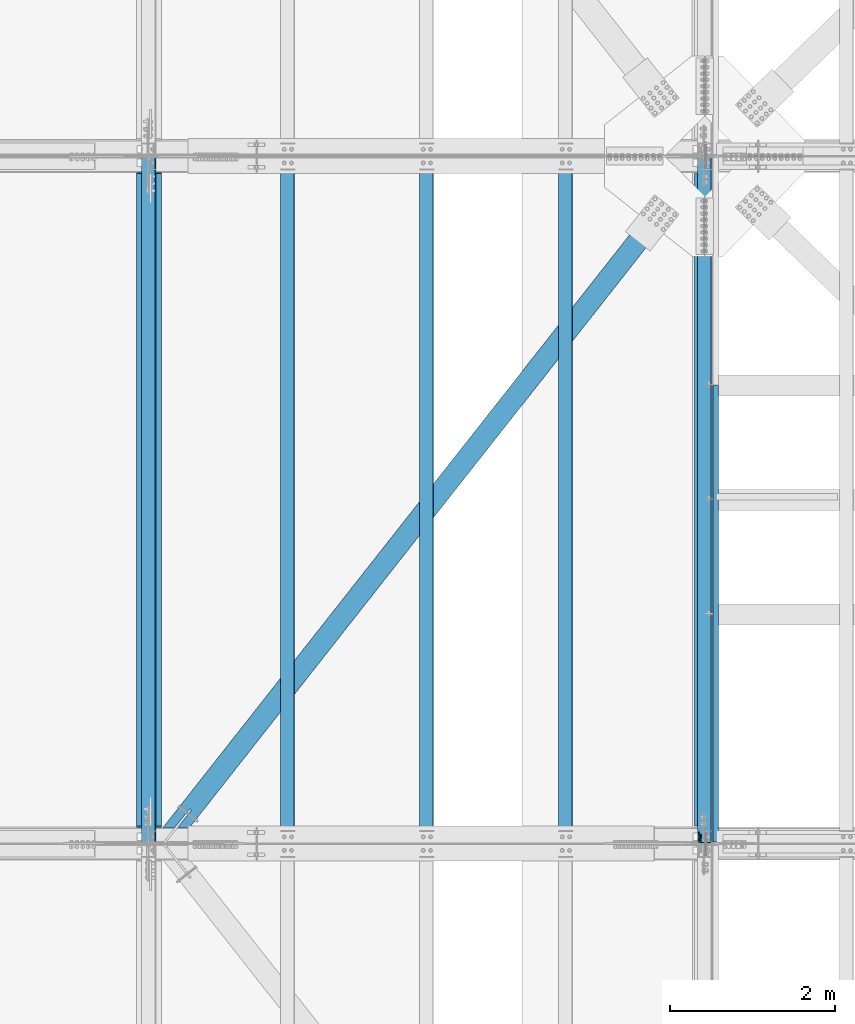
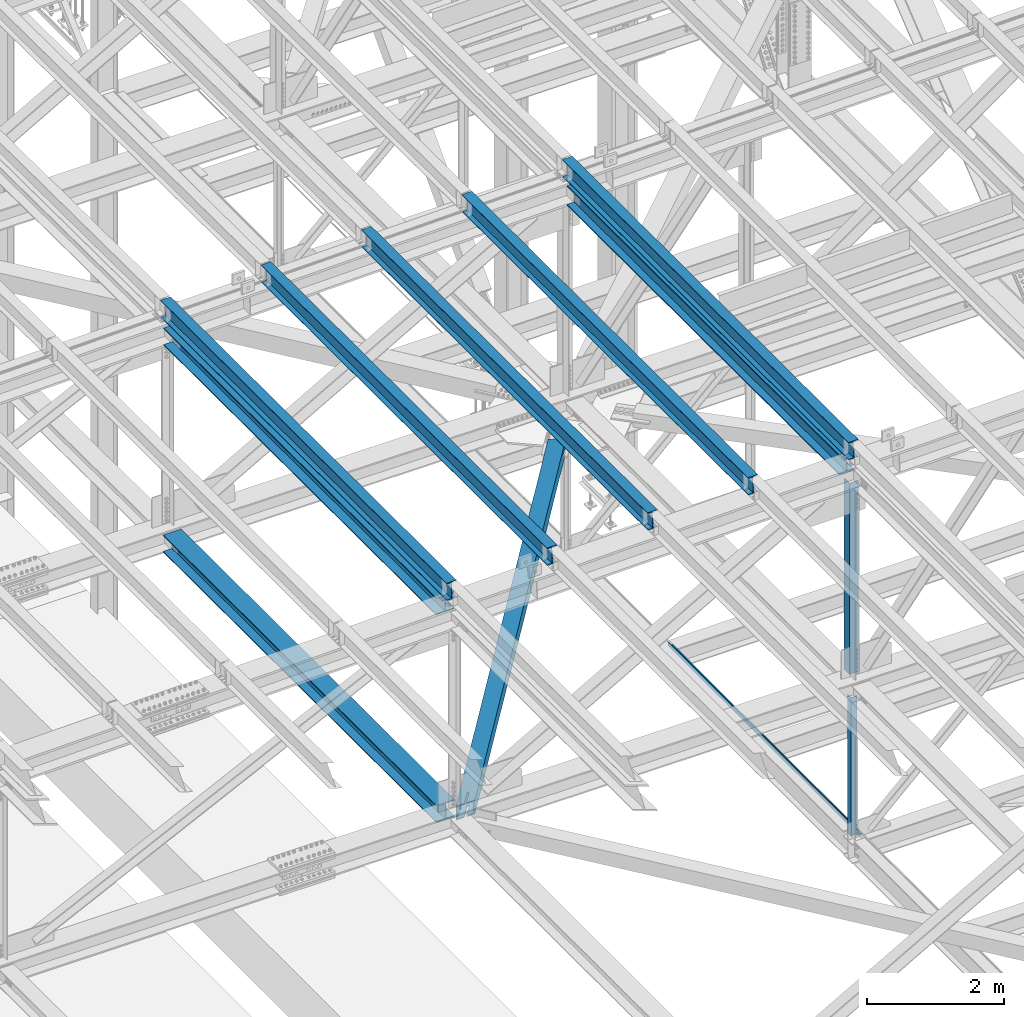
# One storey, part 1902 of 3843: 12 beams, 12 elements without a shape of their own.
"""IFC2X3 building model written with IfcOpenShell, lengths in millimetres."""

from ifc_helpers import new_model, si_unit, frame, origin_with_axes, place, context, subcontext, project, spatial, faceted_brep, material, type_object, element, aggregate, save


model = new_model("IFC2X3")

# Units and contexts
model_context = context("Model", 3, precision=1e-05, world=origin_with_axes())
body_context = subcontext(model_context, "Body", "Model", "MODEL_VIEW")
ifc_project = project(units=[si_unit("LENGTHUNIT", "METRE", prefix="MILLI"), si_unit("AREAUNIT", "SQUARE_METRE"), si_unit("VOLUMEUNIT", "CUBIC_METRE"), si_unit("MASSUNIT", "GRAM", prefix="KILO"), si_unit("TIMEUNIT", "SECOND"), si_unit("PLANEANGLEUNIT", "RADIAN"), si_unit("SOLIDANGLEUNIT", "STERADIAN"), si_unit("THERMODYNAMICTEMPERATUREUNIT", "DEGREE_CELSIUS"), si_unit("LUMINOUSINTENSITYUNIT", "LUMEN")], contexts=[model_context])

# Site, building, storey
site_placement = place(None, origin_with_axes())
site = spatial("IfcSite", under=ifc_project, at=site_placement, CompositionType="ELEMENT")
building_placement = place(site_placement, origin_with_axes())
building = spatial("IfcBuilding", under=site, at=building_placement, Name="Undefined", CompositionType="ELEMENT")
storey_placement = place(building_placement, origin_with_axes())
storey = spatial("IfcBuildingStorey", under=building, at=storey_placement, Name="Undefined", CompositionType="ELEMENT", Elevation=0.0)

# Assembly, beam
assembly_1_placement = place(storey_placement, origin_with_axes())
assembly_1 = element("IfcElementAssembly", 1, at=assembly_1_placement, inside=storey, Name="ANGLE", AssemblyPlace="NOTDEFINED", PredefinedType="RIGID_FRAME")
ifc_material_1 = material(Name="STEEL/A572-50")
beam_type_1 = type_object("IfcBeamType", Name="L4X4X3/8", PredefinedType="NOTDEFINED")
beam_1_placement = place(assembly_1_placement, frame((77012.8000007959, 67332.225, 42337.7620892171), z_axis=(0.0, 1.0, 0.0), x_axis=(0.0, 0.0, -1.0)))
beam_1 = element("IfcBeam", 2, at=beam_1_placement, type_object=beam_type_1, material=ifc_material_1, Name="ANGLE", ObjectType="L4X4X3/8", context=body_context, shape_type="Brep", body=[
    faceted_brep([(209.619404954581, 50.8000000000029, -50.8000000000029), (209.619404954581, 50.8000000000029, 50.8000000000029), (2671.51558679621, 50.8000000000029, 50.8000000000029), (2671.51558679621, 50.8000000000029, -50.8000000000029), (209.619404954581, 41.2749999999942, 50.8000000000029), (2671.51558679621, 41.2749999999942, 50.8000000000029), (209.619404954581, 41.2749999999942, -41.2749999999942), (2671.51558679621, 41.2749999999942, -41.2749999999942), (209.619404954581, -50.8000000000029, -41.2749999999942), (2671.51558679621, -50.8000000000029, -41.2749999999942), (209.619404954581, -50.8000000000029, -50.8000000000029), (2671.51558679621, -50.8000000000029, -50.8000000000029)], [[[0, 1, 2, 3]], [[1, 4, 5, 2]], [[4, 6, 7, 5]], [[6, 8, 9, 7]], [[8, 10, 11, 9]], [[10, 0, 3, 11]], [[5, 7, 9, 11, 3, 2]], [[10, 8, 6, 4, 1, 0]]]),
])
aggregate(assembly_1, [beam_1])

assembly_2_placement = place(storey_placement, origin_with_axes())
assembly_2 = element("IfcElementAssembly", 3, at=assembly_2_placement, inside=storey, Name="BEAM", AssemblyPlace="NOTDEFINED", PredefinedType="RIGID_FRAME")
ifc_material_2 = material(Name="STEEL/A992")
beam_type_2 = type_object("IfcBeamType", Name="W12X26", PredefinedType="NOTDEFINED")
beam_2_placement = place(assembly_2_placement, frame((77009.5092623547, 67272.2367402052, 46520.5581459904), z_axis=(-0.02115209757931, 0.00216448800069338, 0.999773926325192), x_axis=(0.0, 0.999997656445371, -0.00216497200096435)))
beam_2 = element("IfcBeam", 4, at=beam_2_placement, type_object=beam_type_2, material=ifc_material_2, Name="BEAM", ObjectType="W12X26", context=body_context, shape_type="Brep", body=[
    faceted_brep([(12.7037963889888, 82.550000000585, -155.57500000039), (12.683193207602, 82.5500000002357, -146.050000000549), (8343.90271783868, 82.5500000001048, -146.049999994), (8343.92333463172, 82.5500000000757, -155.574999994024), (12.6795583240309, 3.17499999979918, -146.050000000425), (8343.8990829551, 3.17499999965366, -146.049999993877), (12.0473100042, 3.17500000025029, 146.050000000447), (8343.26683463529, 3.17500000011933, 146.050000006988), (12.050944887771, 82.5500000007014, 146.050000000316), (8343.27046951886, 82.5500000005559, 146.050000006871), (12.0303280947264, 82.5500000007014, 155.575000000354), (8343.24985272581, 82.5500000005704, 155.575000006902), (12.0227675369097, -82.5500000002212, 155.575000000594), (8343.24229216801, -82.5500000003667, 155.575000007149), (12.0433843299543, -82.5500000002357, 146.05000000057), (8343.26290896104, -82.5500000003813, 146.050000007119), (12.0470192135253, -3.17499999978463, 146.050000000454), (8343.26654384461, -3.17499999993015, 146.050000006995), (12.6792675333563, -3.17500000025029, -146.050000000425), (8343.89879216443, -3.17500000038126, -146.049999993869), (12.6756326497853, -82.5500000006869, -146.050000000301), (8343.89510752616, -82.549999962459, -146.049999975388), (12.6962628250476, -82.5500000003522, -155.574999999924), (8343.9157740739, -82.5500000008324, -155.574999993776)], [[[0, 1, 2, 3]], [[1, 4, 5, 2]], [[4, 6, 7, 5]], [[6, 8, 9, 7]], [[8, 10, 11, 9]], [[10, 12, 13, 11]], [[12, 14, 15, 13]], [[14, 16, 17, 15]], [[16, 18, 19, 17]], [[18, 20, 21, 19]], [[20, 22, 23, 21]], [[22, 0, 3, 23]], [[5, 7, 9, 11, 13, 15, 17, 19, 21, 23, 3, 2]], [[22, 20, 18, 16, 14, 12, 10, 8, 6, 4, 1, 0]]]),
])
aggregate(assembly_2, [beam_2])

assembly_3_placement = place(storey_placement, origin_with_axes())
assembly_3 = element("IfcElementAssembly", 5, at=assembly_3_placement, inside=storey, Name="BEAM", AssemblyPlace="NOTDEFINED", PredefinedType="RIGID_FRAME")
beam_3_placement = place(assembly_3_placement, frame((70253.109262355, 67272.2253246487, 46384.0531792137), z_axis=(-0.0211520982737129, 0.00209111100100563, 0.999774082477337), x_axis=(0.0, 0.999997812646253, -0.00209157899925994)))
beam_3 = element("IfcBeam", 6, at=beam_3_placement, type_object=beam_type_2, material=ifc_material_2, Name="BEAM", ObjectType="W12X26", context=body_context, shape_type="Brep", body=[
    faceted_brep([(12.7036798584013, 82.5500000007596, -155.574999999946), (12.6837619820581, 82.5500000007451, -146.049999999937), (8343.90198525623, 82.5500000010506, -146.050000014387), (8343.92190313258, 82.5500000010652, -155.575000014403), (12.6802503225917, 3.1750000003085, -146.050000000148), (8343.89847359677, 3.17500000061409, -146.050000014606), (12.0694354482985, 3.17499999974098, 146.050000000119), (8343.28765872247, 3.17500000004657, 146.049999985662), (12.0729471077648, 82.5500000001775, 146.050000000338), (8343.29117038194, 82.5500000004831, 146.04999998588), (12.0530292314361, 82.550000000163, 155.575000000346), (8343.2712525056, 82.5500000004831, 155.574999985889), (12.0457249797328, -82.5500000007596, 155.574999999895), (8343.26394825391, -82.550000000454, 155.574999985445), (12.065642856076, -82.5500000007451, 146.049999999886), (8343.28386613025, -82.5500000004395, 146.049999985436), (12.0691545155423, -3.17500000029395, 146.050000000105), (8343.28737778972, -3.17499999998836, 146.049999985647), (12.6799693898356, -3.17499999974098, -146.05000000017), (8343.89819266401, -3.17499999943539, -146.050000014628), (12.6764577303547, -82.5500000001921, -146.050000000381), (8343.89468100455, -82.5499999998865, -146.050000014839), (12.696375606698, -82.550000000163, -155.57500000039), (8343.91459888089, -82.5499999998574, -155.575000014847)], [[[0, 1, 2, 3]], [[1, 4, 5, 2]], [[4, 6, 7, 5]], [[6, 8, 9, 7]], [[8, 10, 11, 9]], [[10, 12, 13, 11]], [[12, 14, 15, 13]], [[14, 16, 17, 15]], [[16, 18, 19, 17]], [[18, 20, 21, 19]], [[20, 22, 23, 21]], [[22, 0, 3, 23]], [[5, 7, 9, 11, 13, 15, 17, 19, 21, 23, 3, 2]], [[22, 20, 18, 16, 14, 12, 10, 8, 6, 4, 1, 0]]]),
])
aggregate(assembly_3, [beam_3])

assembly_4_placement = place(storey_placement, origin_with_axes())
assembly_4 = element("IfcElementAssembly", 7, at=assembly_4_placement, inside=storey, Name="BEAM", AssemblyPlace="NOTDEFINED", PredefinedType="RIGID_FRAME")
beam_4_placement = place(assembly_4_placement, frame((75320.4094463182, 67272.2363840141, 46487.3259265491), z_axis=(-0.0211520975208841, 0.00216219800061662, 0.999773931281604), x_axis=(-2.1999999147417e-08, 0.999997661398384, -0.00216268300086169)))
beam_4 = element("IfcBeam", 8, at=beam_4_placement, type_object=beam_type_2, material=ifc_material_2, Name="BEAM", ObjectType="W12X26", context=body_context, shape_type="Brep", body=[
    faceted_brep([(12.7037963889888, 82.550000000585, -155.57500000039), (12.6832505025814, 82.550000000585, -146.050000000381), (8343.90271783868, 82.5500000001048, -146.049999994), (8343.92333463172, 82.5500000000757, -155.574999994024), (12.6796285968449, 3.17500000013388, -146.050000000163), (8343.89901918435, 3.17500003804162, -146.049999975628), (12.0480003569392, 3.17500000042492, 146.04999999969), (8343.26748387654, 3.17500002078305, 146.050000020252), (12.0516331437248, 82.550000000876, 146.049999999414), (8343.27111666334, 82.5500000212342, 146.050000019983), (12.0310381532472, 82.5500000009051, 155.574999999386), (8343.25052167283, 82.5500000212778, 155.575000019962), (12.0234819566831, -82.550000000032, 155.574999999953), (8343.24296547628, -82.5499999796739, 155.57500002053), (12.0440769471606, -82.5500000000611, 146.049999999988), (8343.26356046677, -82.549999979703, 146.050000020543), (12.0477097339899, -3.17499999961001, 146.049999999705), (8343.26719325357, -3.17499997923733, 146.050000020281), (12.6793388443766, -3.1749999999156, -146.050000000141), (8343.89872943189, -3.17499996200786, -146.049999975599), (12.6756326497853, -82.5500000006869, -146.050000000301), (8343.89510752616, -82.549999962459, -146.049999975388), (12.6962628250476, -82.5500000003522, -155.574999999924), (8343.9157740739, -82.5500000008324, -155.574999993776)], [[[0, 1, 2, 3]], [[1, 4, 5, 2]], [[4, 6, 7, 5]], [[6, 8, 9, 7]], [[8, 10, 11, 9]], [[10, 12, 13, 11]], [[12, 14, 15, 13]], [[14, 16, 17, 15]], [[16, 18, 19, 17]], [[18, 20, 21, 19]], [[20, 22, 23, 21]], [[22, 0, 3, 23]], [[5, 7, 9, 11, 13, 15, 17, 19, 21, 23, 3, 2]], [[22, 20, 18, 16, 14, 12, 10, 8, 6, 4, 1, 0]]]),
])
aggregate(assembly_4, [beam_4])

assembly_5_placement = place(storey_placement, origin_with_axes())
assembly_5 = element("IfcElementAssembly", 9, at=assembly_5_placement, inside=storey, Name="BEAM", AssemblyPlace="NOTDEFINED", PredefinedType="RIGID_FRAME")
beam_5_placement = place(assembly_5_placement, frame((73631.3092623312, 67272.2334284591, 46453.4642094914), z_axis=(-0.0211520976140747, 0.00214229500025977, 0.99977397412548), x_axis=(-2.20000000902242e-08, 0.999997704255013, -0.00214277500054673)))
beam_5 = element("IfcBeam", 10, at=beam_5_placement, type_object=beam_type_2, material=ifc_material_2, Name="BEAM", ObjectType="W12X26", context=body_context, shape_type="Brep", body=[
    faceted_brep([(12.7037963889888, 82.550000000585, -155.57500000039), (12.68336709289, 82.5499999996246, -146.050000000039), (8343.90246569729, 82.5499999989333, -146.049999980707), (8343.92289895112, 82.5500000208558, -155.575000023666), (12.6797677313734, 3.17499999917345, -146.049999999879), (8343.89889418155, 3.1750000204629, -146.050000023519), (12.0537287846819, 3.1750000006723, 146.05000000052), (8343.27287122235, 3.17500000084692, 146.049999992661), (12.0573279195814, 82.5500000011234, 146.050000000359), (8343.27647035726, 82.550000001298, 146.049999992501), (12.0369138889801, 82.5500000011671, 155.575000000397), (8343.25605632665, 82.5500000013417, 155.574999992539), (12.0294276883797, -82.5499999997555, 155.57500000071), (8343.24857012604, -82.5499999995955, 155.574999992859), (12.049841718981, -82.5499999997992, 146.05000000068), (8343.26898415665, -82.5499999996246, 146.049999992829), (12.0534408538806, -3.17499999934807, 146.05000000052), (8343.27258329155, -3.17499999917345, 146.049999992669), (12.679479782455, -3.17500000086147, -146.049999999857), (8343.89860623263, -3.17499997957202, -146.050000023497), (12.6758804209385, -82.550000001298, -146.049999999705), (8343.89500687108, -82.5499999800086, -146.050000023337), (12.6962628250476, -82.5500000003522, -155.574999999924), (8343.91541227915, -82.5499999800668, -155.575000023331)], [[[0, 1, 2, 3]], [[1, 4, 5, 2]], [[4, 6, 7, 5]], [[6, 8, 9, 7]], [[8, 10, 11, 9]], [[10, 12, 13, 11]], [[12, 14, 15, 13]], [[14, 16, 17, 15]], [[16, 18, 19, 17]], [[18, 20, 21, 19]], [[20, 22, 23, 21]], [[22, 0, 3, 23]], [[5, 7, 9, 11, 13, 15, 17, 19, 21, 23, 3, 2]], [[22, 20, 18, 16, 14, 12, 10, 8, 6, 4, 1, 0]]]),
])
aggregate(assembly_5, [beam_5])

assembly_6_placement = place(storey_placement, origin_with_axes())
assembly_6 = element("IfcElementAssembly", 11, at=assembly_6_placement, inside=storey, Name="BEAM", AssemblyPlace="NOTDEFINED", PredefinedType="RIGID_FRAME")
beam_6_placement = place(assembly_6_placement, frame((71942.2094462516, 67272.2310134095, 46419.0794002078), z_axis=(-0.0211520979537891, 0.00212767700070982, 0.999774005334573), x_axis=(-2.20000007768643e-08, 0.99999773547771, -0.00212815400101693)))
beam_6 = element("IfcBeam", 12, at=beam_6_placement, type_object=beam_type_2, material=ifc_material_2, Name="BEAM", ObjectType="W12X26", context=body_context, shape_type="Brep", body=[
    faceted_brep([(12.7037963889888, 82.550000000585, -155.57500000039), (12.683480394975, 82.5500000002939, -146.049999999464), (8343.90234657429, 82.5500000214379, -146.050000015632), (8343.92261274744, 82.5500000214088, -155.575000015604), (12.6799055809533, 3.17499999984284, -146.049999999574), (8343.89877176027, 3.17500002098677, -146.050000015734), (12.058409604826, 3.17500000023574, 146.049999999545), (8343.27727578412, 3.17500002136512, 146.049999983385), (12.0619844188186, 82.5500000006869, 146.049999999639), (8343.28085059814, 82.5500000218162, 146.049999983486), (12.0417182456877, 82.5500000006869, 155.574999999611), (8343.26058442501, 82.5500000218308, 155.574999983459), (12.0342826325505, -82.5500000002357, 155.574999999408), (8343.25314881184, -82.5499999790918, 155.574999983255), (12.0545488056814, -82.5500000002503, 146.049999999435), (8343.27341498497, -82.5499999791209, 146.049999983283), (12.0581236196886, -3.17499999979918, 146.049999999545), (8343.27698979899, -3.1749999786698, 146.049999983377), (12.6796195958304, -3.17500000017753, -146.049999999581), (8343.89848577516, -3.1749999790336, -146.050000015734), (12.6760447818233, -82.5500000006286, -146.049999999683), (8343.89491096114, -82.5499999794847, -146.050000015828), (12.6962628250476, -82.5500000003522, -155.574999999924), (8343.91517713427, -82.5499999795138, -155.5750000158)], [[[0, 1, 2, 3]], [[1, 4, 5, 2]], [[4, 6, 7, 5]], [[6, 8, 9, 7]], [[8, 10, 11, 9]], [[10, 12, 13, 11]], [[12, 14, 15, 13]], [[14, 16, 17, 15]], [[16, 18, 19, 17]], [[18, 20, 21, 19]], [[20, 22, 23, 21]], [[22, 0, 3, 23]], [[5, 7, 9, 11, 13, 15, 17, 19, 21, 23, 3, 2]], [[22, 20, 18, 16, 14, 12, 10, 8, 6, 4, 1, 0]]]),
])
aggregate(assembly_6, [beam_6])

assembly_7_placement = place(storey_placement, origin_with_axes())
assembly_7 = element("IfcElementAssembly", 13, at=assembly_7_placement, inside=storey, Name="BENT_PLATE", AssemblyPlace="NOTDEFINED", PredefinedType="RIGID_FRAME")
ifc_material_3 = material(Name="STEEL/A36")
beam_type_3 = type_object("IfcBeamType", PredefinedType="NOTDEFINED")
beam_7_placement = place(assembly_7_placement, frame((77179.4875000013, 70066.69375, 39627.1749999995), z_axis=(0.0, 1.0, 0.0), x_axis=(-1.0, 0.0, 0.0)))
beam_7 = element("IfcBeam", 14, at=beam_7_placement, type_object=beam_type_3, material=ifc_material_3, Name="BENT_PLATE", context=body_context, shape_type="Brep", body=[
    faceted_brep([(0.0, -3.17500000000291, -2776.53750000001), (0.0, -3.17500000000291, 2776.53750000001), (0.0, 3.17500000000291, 2776.53750000001), (0.0, 3.17500000000291, -2776.53750000001), (69.8500000010827, 3.17500000000291, 2776.53750000001), (69.8500000010827, 3.17500000000291, -2776.53750000001), (76.2000000010739, -3.17500000000291, -2776.53750000001), (76.2000000010739, -3.17500000000291, 2776.53750000001), (69.8500000011554, 73.0249999989392, 2776.53750000001), (69.8500000011554, 73.0249999989392, -2776.53750000001), (76.2000000011612, 73.0249999989246, 2776.53750000001), (76.2000000011612, 73.0249999989246, -2776.53750000001)], [[[0, 1, 2, 3]], [[3, 2, 4, 5]], [[1, 0, 6, 7]], [[5, 4, 8, 9]], [[4, 2, 1, 7, 10, 8]], [[7, 6, 11, 10]], [[6, 0, 3, 5, 9, 11]], [[10, 11, 9, 8]]]),
])
aggregate(assembly_7, [beam_7])

assembly_8_placement = place(storey_placement, origin_with_axes())
assembly_8 = element("IfcElementAssembly", 15, at=assembly_8_placement, inside=storey, Name="ANGLE", AssemblyPlace="NOTDEFINED", PredefinedType="RIGID_FRAME")
beam_type_4 = type_object("IfcBeamType", Name="L6X6X1/2", PredefinedType="NOTDEFINED")
beam_8_placement = place(assembly_8_placement, frame((77012.7999988756, 67357.625, 46168.1307259776), z_axis=(0.0, 1.0, 0.0), x_axis=(0.0, 0.0, -1.0)))
beam_8 = element("IfcBeam", 16, at=beam_8_placement, type_object=beam_type_4, material=ifc_material_1, Name="ANGLE", ObjectType="L6X6X1/2", context=body_context, shape_type="Brep", body=[
    faceted_brep([(223.145843578597, 76.1999999999971, -76.1999999999971), (223.145843578597, 76.1999999999971, 76.1999999999971), (3620.01394118612, 76.1999999999971, 76.1999999999971), (3620.01394118612, 76.1999999999971, -76.1999999999971), (223.145843578597, 63.5, 76.1999999999971), (3620.01394118612, 63.5, 76.1999999999971), (223.145843578597, 63.5, -63.5), (3620.01394118612, 63.5, -63.5), (223.145843578597, -76.1999999999971, -63.5), (3620.01394118612, -76.1999999999971, -63.5), (223.145843578597, -76.1999999999971, -76.1999999999971), (3620.01394118612, -76.1999999999971, -76.1999999999971)], [[[0, 1, 2, 3]], [[1, 4, 5, 2]], [[4, 6, 7, 5]], [[6, 8, 9, 7]], [[8, 10, 11, 9]], [[10, 0, 3, 11]], [[5, 7, 9, 11, 3, 2]], [[10, 8, 6, 4, 1, 0]]]),
])
aggregate(assembly_8, [beam_8])

assembly_9_placement = place(storey_placement, origin_with_axes())
assembly_9 = element("IfcElementAssembly", 17, at=assembly_9_placement, inside=storey, AssemblyPlace="NOTDEFINED", PredefinedType="RIGID_FRAME")
ifc_material_4 = material()
beam_type_5 = type_object("IfcBeamType", Name="HSS10X10X3/4", PredefinedType="NOTDEFINED")
beam_9_placement = place(assembly_9_placement, frame((70434.2, 67271.9, 42246.55), z_axis=(0.785737878354044, -0.61855960627872, 0.0), x_axis=(0.618559606278724, 0.785737878354041, 0.0)))
beam_9 = element("IfcBeam", 18, at=beam_9_placement, type_object=beam_type_5, material=ifc_material_4, ObjectType="HSS10X10X3/4", context=body_context, shape_type="Brep", body=[
    faceted_brep([(516.209344809561, -107.949999999997, 14.2875004909001), (516.209344809561, -127.0, 14.2875004909001), (263.796845348849, -127.0, 14.2875004904345), (263.796845348849, -107.949999999997, 14.2875004904345), (521.676934495421, -107.949999999997, 13.1999292826367), (521.676934495421, -127.0, 13.1999292826367), (526.312133215446, -107.949999999997, 10.1027885154035), (526.312133215446, -127.0, 10.1027885154035), (529.409273982694, -107.949999999997, 5.46758979538572), (529.409273982694, -127.0, 5.46758979538572), (516.209344809772, -127.0, -14.2874995075981), (516.209344809772, -107.949999999997, -14.2874995075981), (241.301632587426, -107.949999999997, -14.2874995080638), (241.301632587426, -127.0, -14.2874995080638), (521.676934495611, -127.0, -13.1999282993202), (521.676934495611, -107.949999999997, -13.1999282993202), (526.312133215585, -127.0, -10.1027875320869), (526.312133215585, -107.949999999997, -10.1027875320869), (529.40927398276, -127.0, -5.4675888120546), (529.40927398276, -107.949999999997, -5.4675888120546), (530.496845191009, -127.0, 1.09503162093461e-07), (530.496845191009, -107.949999999997, 1.09503162093461e-07), (516.209344809561, 127.0, 14.2875004909001), (516.209344809561, 107.949999999997, 14.2875004909001), (263.796845348849, 107.949999999997, 14.2875004904345), (263.796845348849, 127.0, 14.2875004904345), (521.676934495421, 127.0, 13.1999292826367), (521.676934495421, 107.949999999997, 13.1999292826367), (526.312133215446, 127.0, 10.1027885154035), (526.312133215446, 107.949999999997, 10.1027885154035), (529.409273982694, 127.0, 5.46758979538572), (529.409273982694, 107.949999999997, 5.46758979538572), (516.209344809772, 107.949999999997, -14.2874995075981), (516.209344809772, 127.0, -14.2874995075981), (241.301632587426, 127.0, -14.2874995080638), (241.301632587426, 107.949999999997, -14.2874995080638), (521.676934495611, 107.949999999997, -13.1999282993202), (521.676934495611, 127.0, -13.1999282993202), (526.312133215585, 107.949999999997, -10.1027875320869), (526.312133215585, 127.0, -10.1027875320869), (529.40927398276, 107.949999999997, -5.4675888120546), (529.40927398276, 127.0, -5.4675888120546), (530.496845191009, 107.949999999997, 1.09503162093461e-07), (530.496845191009, 127.0, 1.09503162093461e-07), (9318.00077363143, -1.58687290176022, -107.950000040411), (9318.00077363134, -1.58687290176022, -127.000000040291), (9312.53318394556, -0.49930169347499, -127.000000040276), (9312.53318394565, -0.49930169347499, -107.95000004039), (9307.89798522559, 2.5978390737655, -127.000000040247), (9307.89798522567, 2.5978390737655, -107.950000040368), (9304.80084445841, 7.2330377938124, -127.000000040247), (9304.8008444585, 7.2330377938124, -107.950000040353), (9303.71327325016, 12.7006267167671, -127.000000040232), (9303.71327325022, 12.7006267167671, -107.950000040353), (9304.80084445841, 18.1682164026643, -127.000000040247), (9304.8008444585, 18.1682164026643, -107.950000040353), (9307.89798522559, 22.8034151227112, -127.000000040247), (9307.89798522567, 22.8034151227112, -107.950000040368), (9312.53318394556, 25.9005558899516, -127.000000040276), (9312.53318394565, 25.9005558899516, -107.95000004039), (9318.00077363134, 26.9881270982369, -127.000000040291), (9318.00077363143, 26.9881270982369, -107.950000040411), (9570.41327335576, 26.9881270982369, -127.000000041411), (9570.41327335576, 26.9881270982369, -107.950000041532), (337.531153461072, -107.949999999997, 107.949999998338), (337.531153461072, 107.949999999997, 107.949999998338), (9570.41327454061, 107.949999999997, 107.950000042016), (9570.41327335578, 26.9881270982369, 107.949999957153), (9318.00077363239, 26.9881270982369, 107.949999958259), (9312.53318394658, 25.9005558899516, 107.949999958288), (9307.89798522663, 22.8034151227112, 107.949999958302), (9304.80084445943, 18.1682164026643, 107.949999958324), (9303.71327325118, 12.7006267167671, 107.949999958324), (9304.80084445943, 7.2330377938124, 107.949999958324), (9307.89798522663, 2.5978390737655, 107.949999958302), (9312.53318394658, -0.49930169347499, 107.949999958288), (9318.00077363239, -1.58687290176022, 107.949999958259), (9570.41327335578, -1.58687290176022, 107.949999957153), (9570.41327454061, -107.949999999997, 107.950000042016), (9570.41327467293, -107.949999999997, -107.949999957629), (167.56732370008, -107.949999999997, -107.950000000565), (9570.41327467293, 107.949999999997, -107.949999957629), (167.56732370008, 107.949999999997, -107.950000000565), (9570.41327335576, -1.58687290176022, -107.950000041532), (9570.41327335576, -1.58687290176022, -127.000000041411), (152.570515191763, -127.0, -127.000000000466), (152.570515191763, 127.0, -127.000000000466), (9570.4132746846, 127.0, -126.999999957603), (9570.4132746846, -127.0, -126.999999957603), (352.527961969396, 127.0, 126.999999998239), (9570.41327452892, 127.0, 127.000000041982), (9570.41327335578, 26.9881270982369, 126.999999957025), (9318.00077363248, 26.9881270982369, 126.999999958145), (9312.53318394667, 25.9005558899516, 126.99999995816), (9307.89798522672, 22.8034151227112, 126.999999958189), (9304.80084445952, 18.1682164026643, 126.999999958189), (9303.71327325127, 12.7006267167671, 126.999999958211), (9304.80084445952, 7.2330377938124, 126.999999958189), (9307.89798522672, 2.5978390737655, 126.999999958189), (9312.53318394667, -0.49930169347499, 126.99999995816), (9318.00077363248, -1.58687290176022, 126.999999958145), (9570.41327335578, -1.58687290176022, 126.999999957025), (9570.41327452892, -127.0, 127.000000041982), (352.527961969396, -127.0, 126.999999998239)], [[[0, 1, 2, 3]], [[1, 0, 4, 5]], [[5, 4, 6, 7]], [[7, 6, 8, 9]], [[10, 11, 12, 13]], [[14, 15, 11, 10]], [[16, 17, 15, 14]], [[18, 19, 17, 16]], [[20, 21, 19, 18]], [[9, 8, 21, 20]], [[22, 23, 24, 25]], [[23, 22, 26, 27]], [[27, 26, 28, 29]], [[29, 28, 30, 31]], [[32, 33, 34, 35]], [[36, 37, 33, 32]], [[38, 39, 37, 36]], [[40, 41, 39, 38]], [[42, 43, 41, 40]], [[31, 30, 43, 42]], [[44, 45, 46, 47]], [[47, 46, 48, 49]], [[49, 48, 50, 51]], [[51, 50, 52, 53]], [[53, 52, 54, 55]], [[55, 54, 56, 57]], [[57, 56, 58, 59]], [[59, 58, 60, 61]], [[61, 60, 62, 63]], [[64, 65, 66, 67, 68, 69, 70, 71, 72, 73, 74, 75, 76, 77, 78]], [[6, 4, 0, 3, 64, 78, 79, 80, 12, 11, 15, 17, 19, 21, 8]], [[44, 47, 49, 51, 53, 55, 57, 59, 61, 63, 81, 82, 80, 79, 83]], [[45, 44, 83, 84]], [[85, 86, 87, 62, 60, 58, 56, 54, 52, 50, 48, 46, 45, 84, 88]], [[80, 82, 35, 34, 86, 85, 13, 12]], [[28, 26, 22, 25, 89, 90, 87, 86, 34, 33, 37, 39, 41, 43, 30]], [[66, 81, 63, 62, 87, 90, 91, 67]], [[92, 68, 67, 91]], [[93, 69, 68, 92]], [[94, 70, 69, 93]], [[95, 71, 70, 94]], [[96, 72, 71, 95]], [[97, 73, 72, 96]], [[98, 74, 73, 97]], [[99, 75, 74, 98]], [[100, 76, 75, 99]], [[76, 100, 101, 77]], [[84, 83, 79, 78, 77, 101, 102, 88]], [[100, 99, 98, 97, 96, 95, 94, 93, 92, 91, 90, 89, 103, 102, 101]], [[16, 14, 10, 13, 85, 88, 102, 103, 2, 1, 5, 7, 9, 20, 18]], [[25, 24, 65, 64, 3, 2, 103, 89]], [[38, 36, 32, 35, 82, 81, 66, 65, 24, 23, 27, 29, 31, 42, 40]]]),
])
aggregate(assembly_9, [beam_9])

assembly_10_placement = place(storey_placement, origin_with_axes())
assembly_10 = element("IfcElementAssembly", 19, at=assembly_10_placement, inside=storey, Name="BEAM", AssemblyPlace="NOTDEFINED", PredefinedType="RIGID_FRAME")
beam_type_6 = type_object("IfcBeamType", Name="W14X68", PredefinedType="NOTDEFINED")
beam_10_placement = place(assembly_10_placement, frame((77012.8, 67271.8999999987, 46168.1307546954), z_axis=(0.0, 0.0021649720009591, 0.999997656445371), x_axis=(0.0, 0.999997656445371, -0.00216497200096435)))
beam_10 = element("IfcBeam", 20, at=beam_10_placement, type_object=beam_type_6, material=ifc_material_2, Name="BEAM", ObjectType="W14X68", context=body_context, shape_type="Brep", body=[
    faceted_brep([(213.110431458015, 127.0, -177.799999999428), (213.069188644731, 127.0, -158.749999999469), (8144.23777573642, 127.0, -158.749999993241), (8144.27901854969, 127.0, -177.799999993193), (213.069188644731, 5.55624999999418, -158.749999999469), (8144.23777573642, 5.55624999999418, -158.749999993241), (212.381808423524, 5.55624999999418, 158.749999999825), (8143.55039551521, 5.55624999999418, 158.750000006054), (212.381808423524, 127.0, 158.749999999825), (8143.55039551521, 127.0, 158.750000006054), (212.34056561024, 127.0, 177.799999999785), (8143.50915270194, 127.0, 177.800000006013), (212.34056561024, -127.0, 177.799999999785), (8143.50915270194, -127.0, 177.800000006013), (212.381808423524, -127.0, 158.749999999825), (8143.55039551521, -127.0, 158.750000006054), (212.381808423524, -5.55624999999418, 158.749999999825), (8143.55039551521, -5.55624999999418, 158.750000006054), (213.069188644731, -5.55624999999418, -158.749999999469), (8144.23777573642, -5.55624999999418, -158.749999993241), (213.069188644731, -127.0, -158.749999999469), (8144.23777573642, -127.0, -158.749999993241), (213.110431458015, -127.0, -177.799999999428), (8144.27901854969, -127.0, -177.799999993193)], [[[0, 1, 2, 3]], [[1, 4, 5, 2]], [[4, 6, 7, 5]], [[6, 8, 9, 7]], [[8, 10, 11, 9]], [[10, 12, 13, 11]], [[12, 14, 15, 13]], [[14, 16, 17, 15]], [[16, 18, 19, 17]], [[18, 20, 21, 19]], [[20, 22, 23, 21]], [[22, 0, 3, 23]], [[5, 7, 9, 11, 13, 15, 17, 19, 21, 23, 3, 2]], [[22, 20, 18, 16, 14, 12, 10, 8, 6, 4, 1, 0]]]),
])
aggregate(assembly_10, [beam_10])

assembly_11_placement = place(storey_placement, origin_with_axes())
assembly_11 = element("IfcElementAssembly", 21, at=assembly_11_placement, inside=storey, Name="BEAM", AssemblyPlace="NOTDEFINED", PredefinedType="RIGID_FRAME")
beam_type_7 = type_object("IfcBeamType", Name="W12X65", PredefinedType="NOTDEFINED")
beam_11_placement = place(assembly_11_placement, frame((70256.4, 67271.8999999994, 46031.6211476753), z_axis=(0.0, 0.00209157899925776, 0.999997812646253), x_axis=(0.0, 0.999997812646253, -0.00209157899925994)))
beam_11 = element("IfcBeam", 22, at=beam_11_placement, type_object=beam_type_7, material=ifc_material_2, Name="BEAM", ObjectType="W12X65", context=body_context, shape_type="Brep", body=[
    faceted_brep([(213.047543032008, 152.399999999994, -153.987499999923), (213.014339142654, 152.399999999994, -138.112499999967), (8144.18168736623, 152.399999999994, -138.112500013733), (8144.21489125559, 152.399999999994, -153.987500013689), (213.014339142654, 4.76249999999709, -138.112499999967), (8144.18168736623, 4.76249999999709, -138.112500013733), (212.436591467835, 4.76249999999709, 138.112499999246), (8143.60393969141, 4.76249999999709, 138.11249998548), (212.436591467835, 152.399999999994, 138.112499999246), (8143.60393969141, 152.399999999994, 138.11249998548), (212.403387578481, 152.399999999994, 153.987499999195), (8143.57073580206, 152.399999999994, 153.987499985436), (212.403387578481, -152.399999999994, 153.987499999195), (8143.57073580206, -152.399999999994, 153.987499985436), (212.436591467835, -152.399999999994, 138.112499999246), (8143.60393969141, -152.399999999994, 138.11249998548), (212.436591467835, -4.76249999999709, 138.112499999246), (8143.60393969141, -4.76249999999709, 138.11249998548), (213.014339142654, -4.76249999999709, -138.112499999967), (8144.18168736623, -4.76249999999709, -138.112500013733), (213.014339142654, -152.399999999994, -138.112499999967), (8144.18168736623, -152.399999999994, -138.112500013733), (213.047543032008, -152.399999999994, -153.987499999923), (8144.21489125559, -152.399999999994, -153.987500013689)], [[[0, 1, 2, 3]], [[1, 4, 5, 2]], [[4, 6, 7, 5]], [[6, 8, 9, 7]], [[8, 10, 11, 9]], [[10, 12, 13, 11]], [[12, 14, 15, 13]], [[14, 16, 17, 15]], [[16, 18, 19, 17]], [[18, 20, 21, 19]], [[20, 22, 23, 21]], [[22, 0, 3, 23]], [[5, 7, 9, 11, 13, 15, 17, 19, 21, 23, 3, 2]], [[22, 20, 18, 16, 14, 12, 10, 8, 6, 4, 1, 0]]]),
])
aggregate(assembly_11, [beam_11])

assembly_12_placement = place(storey_placement, origin_with_axes())
assembly_12 = element("IfcElementAssembly", 23, at=assembly_12_placement, inside=storey, Name="BEAM", AssemblyPlace="NOTDEFINED", PredefinedType="RIGID_FRAME")
beam_12_placement = place(assembly_12_placement, frame((70256.4, 67271.9, 42344.1673578885), z_axis=(0.0, 0.00209298399939144, 0.99999780970659), x_axis=(0.0, 0.99999780970659, -0.00209298399938549)))
beam_12 = element("IfcBeam", 24, at=beam_12_placement, type_object=beam_type_7, material=ifc_material_2, Name="BEAM", ObjectType="W12X65", context=body_context, shape_type="Brep", body=[
    faceted_brep([(198.760225705453, 152.399999999994, -153.987500000294), (198.726999511578, 152.399999999994, -138.112500000338), (8158.46943665209, 152.399999999994, -138.112500028808), (8158.50266284596, 152.399999999994, -153.987500028772), (198.726999511578, 4.76249999999709, -138.112500000338), (8158.46943665209, 4.76249999999709, -138.112500028808), (198.148863738053, 4.76249999999709, 138.112499998926), (8157.89130087856, 4.76249999999709, 138.112499970455), (198.148863738053, 152.399999999994, 138.112499998926), (8157.89130087856, 152.399999999994, 138.112499970455), (198.115637544164, 152.399999999994, 153.987499998882), (8157.85807468467, 152.399999999994, 153.987499970412), (198.115637544164, -152.399999999994, 153.987499998882), (8157.85807468467, -152.399999999994, 153.987499970412), (198.148863738053, -152.399999999994, 138.112499998926), (8157.89130087856, -152.399999999994, 138.112499970455), (198.148863738053, -4.76249999999709, 138.112499998926), (8157.89130087856, -4.76249999999709, 138.112499970455), (198.726999511578, -4.76249999999709, -138.112500000338), (8158.46943665209, -4.76249999999709, -138.112500028808), (198.726999511578, -152.399999999994, -138.112500000338), (8158.46943665209, -152.399999999994, -138.112500028808), (198.760225705453, -152.399999999994, -153.987500000294), (8158.50266284596, -152.399999999994, -153.987500028772)], [[[0, 1, 2, 3]], [[1, 4, 5, 2]], [[4, 6, 7, 5]], [[6, 8, 9, 7]], [[8, 10, 11, 9]], [[10, 12, 13, 11]], [[12, 14, 15, 13]], [[14, 16, 17, 15]], [[16, 18, 19, 17]], [[18, 20, 21, 19]], [[20, 22, 23, 21]], [[22, 0, 3, 23]], [[5, 7, 9, 11, 13, 15, 17, 19, 21, 23, 3, 2]], [[22, 20, 18, 16, 14, 12, 10, 8, 6, 4, 1, 0]]]),
])
aggregate(assembly_12, [beam_12])

save(model, "model.ifc")
